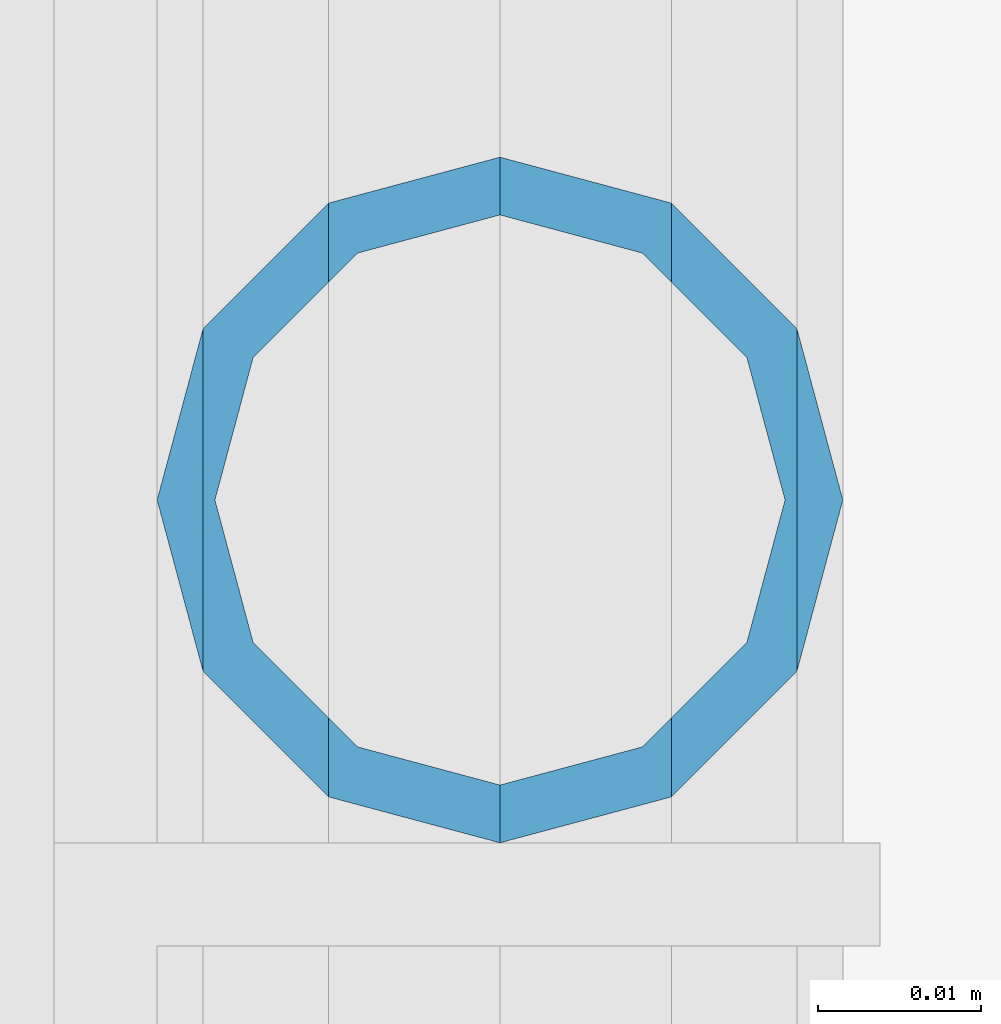
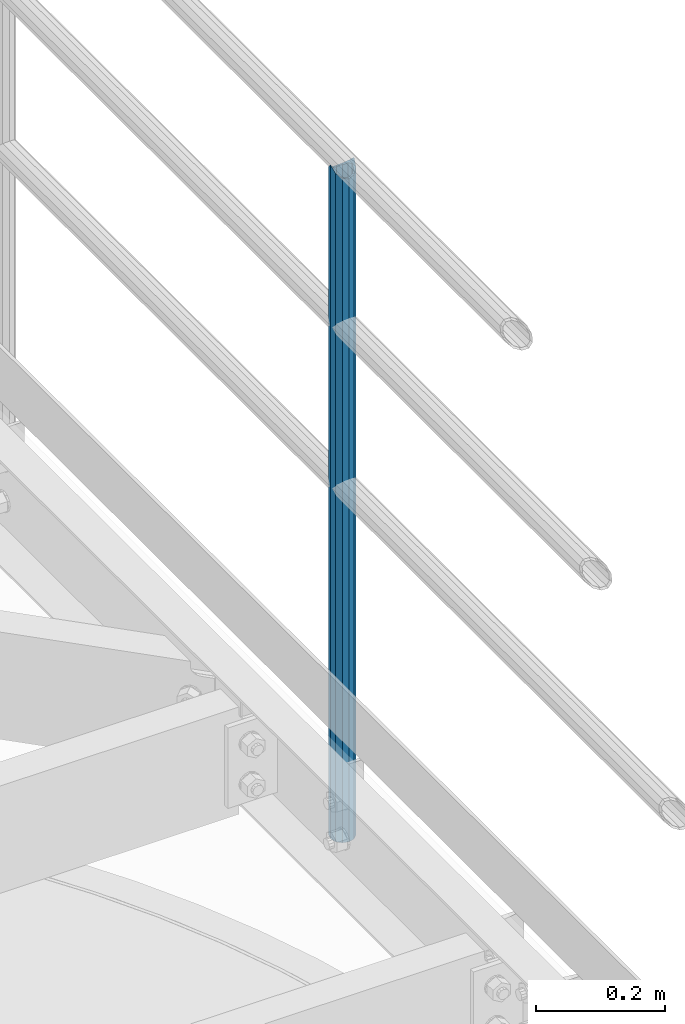
# One storey, part 549 of 1876: 1 column, 1 element without a shape of its own.
"""IFC2X3 building model written with IfcOpenShell, lengths in millimetres."""

from ifc_helpers import new_model, si_unit, frame, origin_with_axes, place, context, subcontext, project, spatial, faceted_brep, material, type_object, element, aggregate, save


model = new_model("IFC2X3")

# Units and contexts
model_context = context("Model", 3, precision=1e-05, world=origin_with_axes())
body_context = subcontext(model_context, "Body", "Model", "MODEL_VIEW")
ifc_project = project(units=[si_unit("LENGTHUNIT", "METRE", prefix="MILLI"), si_unit("AREAUNIT", "SQUARE_METRE"), si_unit("VOLUMEUNIT", "CUBIC_METRE"), si_unit("MASSUNIT", "GRAM", prefix="KILO"), si_unit("TIMEUNIT", "SECOND"), si_unit("PLANEANGLEUNIT", "RADIAN"), si_unit("SOLIDANGLEUNIT", "STERADIAN"), si_unit("THERMODYNAMICTEMPERATUREUNIT", "DEGREE_CELSIUS"), si_unit("LUMINOUSINTENSITYUNIT", "LUMEN")], contexts=[model_context])

# Site, building, storey
site_placement = place(None, origin_with_axes())
site = spatial("IfcSite", under=ifc_project, at=site_placement, CompositionType="ELEMENT")
building_placement = place(site_placement, origin_with_axes())
building = spatial("IfcBuilding", under=site, at=building_placement, Name="Undefined", CompositionType="ELEMENT")
storey_placement = place(building_placement, origin_with_axes())
storey = spatial("IfcBuildingStorey", under=building, at=storey_placement, Name="Undefined", CompositionType="ELEMENT", Elevation=0.0)

# Assembly, column
assembly_placement = place(storey_placement, origin_with_axes())
assembly = element("IfcElementAssembly", 1, at=assembly_placement, inside=storey, Name="HANDRAIL", AssemblyPlace="NOTDEFINED", PredefinedType="RIGID_FRAME")
ifc_material = material()
column_type = type_object("IfcColumnType", Name="PIPE1-1/4STD", PredefinedType="NOTDEFINED")
column_placement = place(assembly_placement, frame((7025.13056849878, -12979.3644042969, 7813.675), z_axis=(0.0, 1.0, 0.0), x_axis=(0.0, 0.0, 1.0)))
column = element("IfcColumn", 2, at=column_placement, type_object=column_type, material=ifc_material, Name="POST", ObjectType="PIPE1-1/4STD", context=body_context, shape_type="Brep", body=[
    faceted_brep([(1258.09245243742, -10.5410000000002, 18.2575475625836), (1258.09245243742, -10.5410017746963, 13.3999594520301), (1257.61603823465, -8.76299999999992, 15.1779612267255), (1255.268, 0.0, 17.5259999999998), (1255.268, 0.0, 21.0820000000003), (1257.6160393119, 8.76299999999992, 15.1779612267255), (1258.09245243742, 10.5409982253032, 13.3999630014223), (1258.09245243742, 10.5410000000002, 18.2575475625836), (1276.35, 21.0820000000003, 0.0), (1265.809, 18.2575475625836, 10.5410000000002), (1265.809, 18.2575475625836, -10.5410000000002), (1262.72941482472, 15.1779612267264, 8.76300000000083), (1265.07745243742, 17.5259999999998, 0.0), (1262.72941250358, 15.1779612267264, -8.76300000000083), (1258.09245243742, 10.5410000000002, -13.3999612267253), (1258.09245243742, 10.5410000000002, -18.2575475625836), (1257.61603877328, 8.76299999999992, -15.1779612267255), (1255.268, 0.0, -17.5259999999998), (1255.268, 0.0, -21.0820000000003), (1258.09245243742, -10.5410000000002, -13.3999612267253), (1258.09245243742, -10.5410000000002, -18.2575475625836), (1257.61603877328, -8.76299999999992, -15.1779612267255), (1276.35000278283, -21.0820000000003, 0.0), (1265.809, -18.2575475625836, -10.5410000000002), (1265.809, -18.2575475625836, 10.5410000000002), (1262.72941366414, -15.1779612267264, -8.76300000000083), (1265.07745243742, -17.5259999999998, 0.0), (1262.72941366414, -15.1779612267264, 8.76300000000083), (0.0, -18.2575475625836, -10.5409999999993), (0.0, -10.5410000000002, -18.2575475625836), (-4.28826751885936e-09, 0.0, -21.0820000000003), (0.0, 10.5410000000002, -18.2575475625836), (0.0, 18.2575475625836, -10.5409999999993), (9.09494701772928e-13, 21.0820000000003, 0.0), (0.0, 18.2575475625836, 10.5409999999993), (0.0, 10.5410000000002, 18.2575475625836), (0.0, 0.0, 21.0820000000003), (0.0, -10.5410000000002, 18.2575475625836), (0.0, -18.2575475625836, 10.5409999999993), (9.09494701772928e-13, -21.0820000000003, 0.0), (0.0, -15.1779612267264, -8.76300000000083), (0.0, -8.76299999999992, -15.1779612267255), (0.0, 0.0, -17.5259999999998), (0.0, 8.76299999999992, -15.1779612267255), (0.0, 15.1779612267264, -8.76300000000083), (0.0, 17.5259999999998, 0.0), (0.0, 15.1779612267264, 8.76300000000083), (0.0, 8.76299999999992, 15.1779612267255), (0.0, 0.0, 17.5259999999998), (0.0, -8.76299999999992, 15.1779612267255), (0.0, -15.1779612267264, 8.76300000000083), (0.0, -17.5259999999998, 0.0)], [[[0, 1, 2, 3, 4]], [[4, 3, 5, 6, 7]], [[8, 9, 10]], [[7, 6, 11, 12, 13, 14, 15, 10, 9]], [[16, 17, 18, 15, 14]], [[19, 20, 18, 17, 21]], [[22, 23, 24]], [[24, 23, 20, 19, 25, 26, 27, 1, 0]], [[28, 29, 20, 23]], [[29, 30, 18, 20]], [[30, 31, 15, 18]], [[31, 32, 10, 15]], [[32, 33, 8, 10]], [[33, 34, 9, 8]], [[34, 35, 7, 9]], [[35, 36, 4, 7]], [[36, 37, 0, 4]], [[37, 38, 24, 0]], [[38, 39, 22, 24]], [[39, 28, 23, 22]], [[38, 37, 36, 35, 34, 33, 32, 31, 30, 29, 28, 39], [40, 41, 42, 43, 44, 45, 46, 47, 48, 49, 50, 51]], [[40, 51, 26, 25]], [[21, 41, 40, 25, 19]], [[42, 41, 21, 17]], [[43, 42, 17, 16]], [[44, 43, 16, 14, 13]], [[45, 44, 13, 12]], [[46, 45, 12, 11]], [[5, 47, 46, 11, 6]], [[48, 47, 5, 3]], [[49, 48, 3, 2]], [[50, 49, 2, 1, 27]], [[51, 50, 27, 26]]]),
])
aggregate(assembly, [column])

save(model, "model.ifc")
